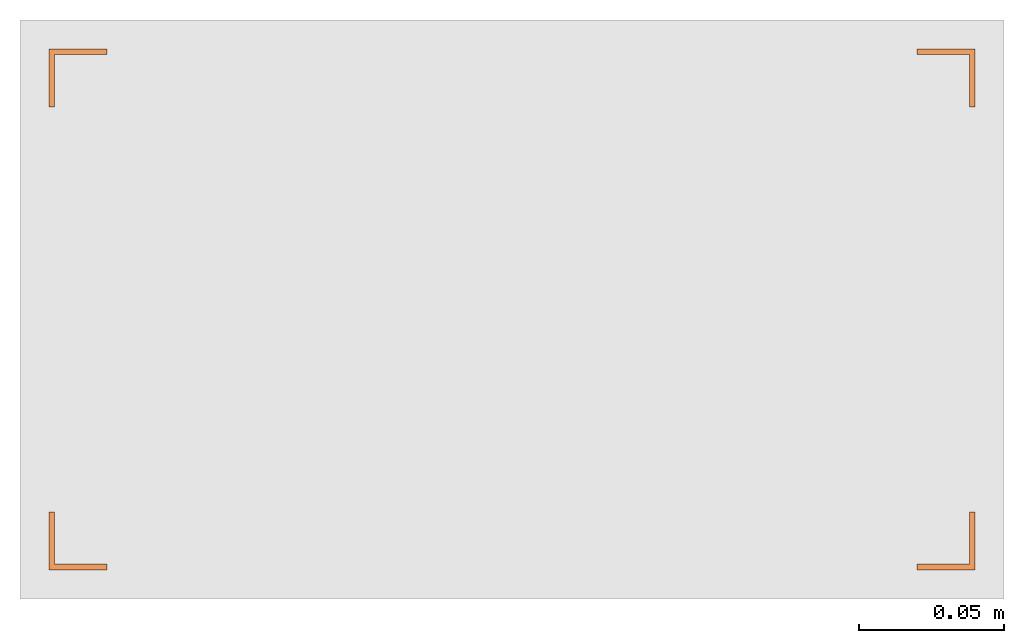
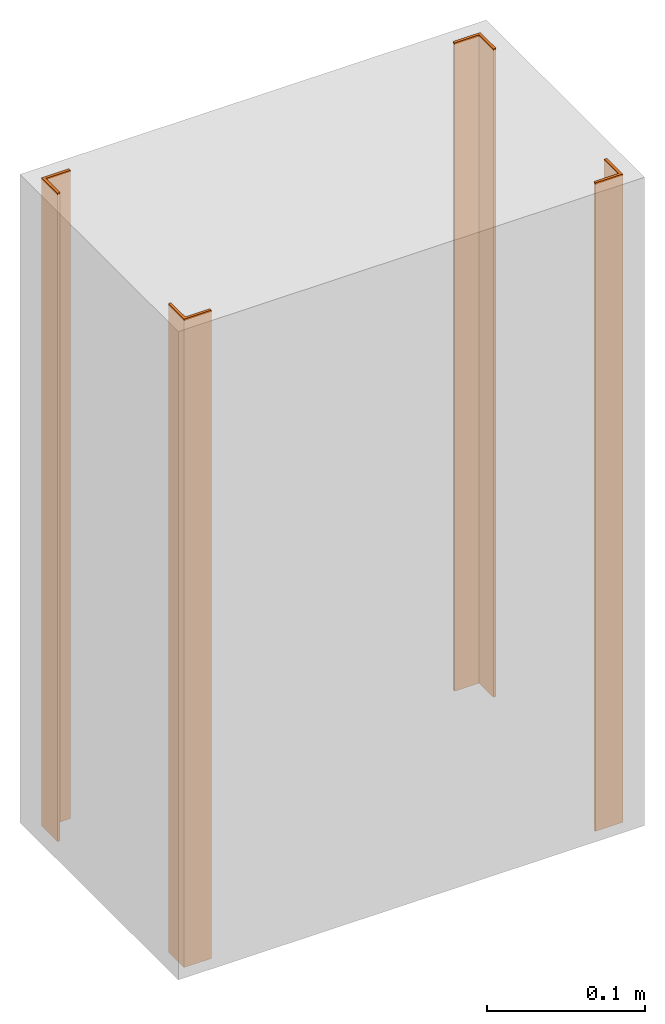
# One storey, part 2 of 2: 4 proxies.
"""IFC2X3 building model written with IfcOpenShell, lengths in millimetres."""

from ifc_helpers import new_model, entity, si_unit, converted_unit, derived_unit, direction, frame, origin, place, context, subcontext, project, spatial, polyline, outline, extrude, source, transform, mapped, type_object, type_shapes, element, save


model = new_model("IFC2X3")

# Units and contexts
model_context = context("Model", 3, precision=0.01, world=origin(), true_north=direction((6.12303176911189e-17, 1.0)))
context_of_model = context(None, 3, precision=0.01, world=origin(), true_north=direction((6.12303176911189e-17, 1.0)))
body_context = subcontext(model_context, "Body", "Model", "MODEL_VIEW")
ifc_project = project(units=[si_unit("LENGTHUNIT", "METRE", prefix="MILLI"), si_unit("AREAUNIT", "SQUARE_METRE"), si_unit("VOLUMEUNIT", "CUBIC_METRE"), converted_unit("PLANEANGLEUNIT", "DEGREE", entity("IfcRatioMeasure", 0.0174532925199433), si_unit("PLANEANGLEUNIT", "RADIAN"), dimensions=[0, 0, 0, 0, 0, 0, 0]), si_unit("MASSUNIT", "GRAM", prefix="KILO"), si_unit("TIMEUNIT", "SECOND"), si_unit("FREQUENCYUNIT", "HERTZ"), si_unit("THERMODYNAMICTEMPERATUREUNIT", "DEGREE_CELSIUS"), derived_unit("THERMALTRANSMITTANCEUNIT", [(si_unit("MASSUNIT", "GRAM", prefix="KILO"), 1), (si_unit("THERMODYNAMICTEMPERATUREUNIT", "KELVIN"), -1), (si_unit("TIMEUNIT", "SECOND"), -3)]), derived_unit("VOLUMETRICFLOWRATEUNIT", [(si_unit("LENGTHUNIT", "METRE"), 3), (si_unit("TIMEUNIT", "SECOND"), -1)]), si_unit("ELECTRICCURRENTUNIT", "AMPERE"), si_unit("ELECTRICVOLTAGEUNIT", "VOLT"), si_unit("POWERUNIT", "WATT"), si_unit("FORCEUNIT", "NEWTON", prefix="KILO"), si_unit("ILLUMINANCEUNIT", "LUX"), si_unit("LUMINOUSFLUXUNIT", "LUMEN"), si_unit("LUMINOUSINTENSITYUNIT", "CANDELA"), si_unit("PRESSUREUNIT", "PASCAL")], contexts=[model_context, context_of_model])

# Site, building, storey
site_placement = place(None, origin())
site = spatial("IfcSite", under=ifc_project, at=site_placement, CompositionType="ELEMENT")
building_placement = place(site_placement, origin())
building = spatial("IfcBuilding", under=site, at=building_placement, CompositionType="ELEMENT")
storey_placement = place(building_placement, origin())
storey = spatial("IfcBuildingStorey", under=building, at=storey_placement, CompositionType="ELEMENT", Elevation=0.0)

# Proxies
building_element_proxy_type_1 = type_object("IfcBuildingElementProxyType", PredefinedType="NOTDEFINED")
shared_shape_1 = source(origin(), body_context, "Body", "SweptSolid", [
    extrude(outline(polyline([(-12.6666666666667, -7.33333333333339), (7.33333333333334, -7.33333333333339), (7.33333333333334, 12.6666666666667), (5.33333333333334, 12.6666666666667), (5.33333333333334, -5.33333333333331), (-12.6666666666667, -5.33333333333331), (-12.6666666666667, -7.33333333333339)])), frame((107.666666666659, 82.6666666666676, 0.0), z_axis=(0.0, 0.0, 1.0), x_axis=(0.0, 1.0, 0.0)), (0.0, 0.0, 1.0), 500.0),
])
type_shapes(building_element_proxy_type_1, [shared_shape_1])
proxy_1_placement = place(storey_placement, frame((-6518.6486027535, 5418.37431996578, 0.0), z_axis=(0.0, 0.0, 1.0), x_axis=(-1.0, 0.0, 0.0)))
element("IfcBuildingElementProxy", 1, at=proxy_1_placement, inside=storey, type_object=building_element_proxy_type_1, context=body_context, shape_type="MappedRepresentation", body=[
    mapped(shared_shape_1, transform((0.0, 0.0, 0.0), scale=1.0)),
])
proxy_2_placement = place(storey_placement, frame((-6428.64860275349, 5418.37431996578, 0.0)))
element("IfcBuildingElementProxy", 2, at=proxy_2_placement, inside=storey, type_object=building_element_proxy_type_1, context=body_context, shape_type="MappedRepresentation", body=[
    mapped(shared_shape_1, transform((0.0, 0.0, 0.0), scale=1.0)),
])
building_element_proxy_type_2 = type_object("IfcBuildingElementProxyType", PredefinedType="NOTDEFINED")
shared_shape_2 = source(origin(), body_context, "Body", "SweptSolid", [
    extrude(outline(polyline([(-7.33333333333336, -12.6666666666667), (-5.33333333333327, -12.6666666666667), (-5.33333333333327, 5.33333333333334), (12.6666666666667, 5.33333333333334), (12.6666666666667, 7.33333333333334), (-7.33333333333336, 7.33333333333334), (-7.33333333333336, -12.6666666666667)])), frame((142.333333333326, 82.6666666666684, 0.0)), (0.0, 0.0, 1.0), 500.0),
])
type_shapes(building_element_proxy_type_2, [shared_shape_2])
proxy_3_placement = place(storey_placement, frame((-6178.6486027535, 5418.37431996578, 0.0), z_axis=(0.0, 0.0, 1.0), x_axis=(-1.0, 0.0, 0.0)))
element("IfcBuildingElementProxy", 3, at=proxy_3_placement, inside=storey, type_object=building_element_proxy_type_2, context=body_context, shape_type="MappedRepresentation", body=[
    mapped(shared_shape_2, transform((0.0, 0.0, 0.0), scale=1.0)),
])
proxy_4_placement = place(storey_placement, frame((-6768.64860275349, 5418.37431996578, 0.0)))
element("IfcBuildingElementProxy", 4, at=proxy_4_placement, inside=storey, type_object=building_element_proxy_type_2, context=body_context, shape_type="MappedRepresentation", body=[
    mapped(shared_shape_2, transform((0.0, 0.0, 0.0), scale=1.0)),
])

save(model, "model.ifc")
